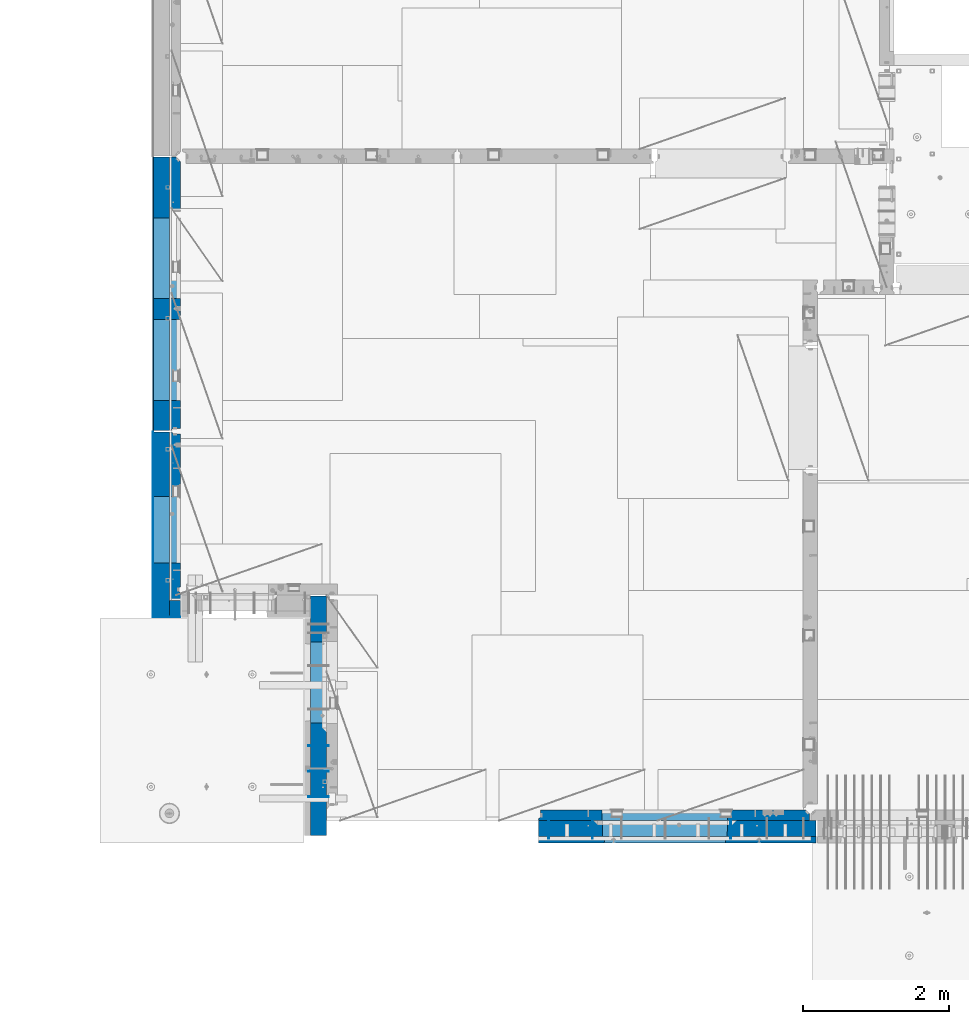
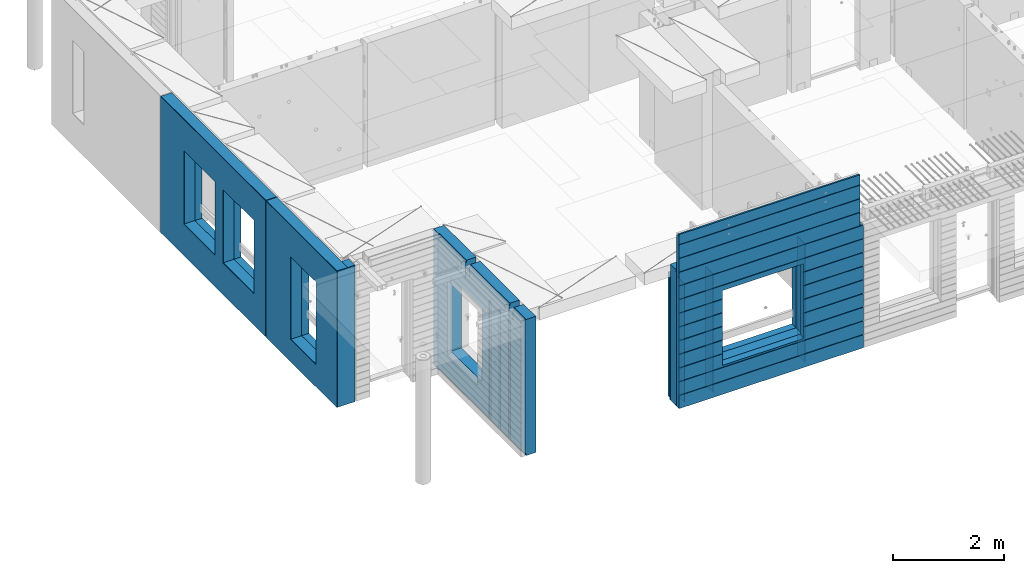
# One storey, part 192 of 309: 18 walls, 4 elements without a shape of their own.
"""IFC2X3 building model written with IfcOpenShell, lengths in millimetres."""

from ifc_helpers import new_model, si_unit, frame, origin_with_axes, place, context, subcontext, project, spatial, faceted_brep, material, type_object, element, aggregate, save


model = new_model("IFC2X3")

# Units and contexts
model_context = context("Model", 3, precision=1e-05, world=origin_with_axes())
body_context = subcontext(model_context, "Body", "Model", "MODEL_VIEW")
ifc_project = project(units=[si_unit("LENGTHUNIT", "METRE", prefix="MILLI"), si_unit("AREAUNIT", "SQUARE_METRE"), si_unit("VOLUMEUNIT", "CUBIC_METRE"), si_unit("MASSUNIT", "GRAM", prefix="KILO"), si_unit("TIMEUNIT", "SECOND"), si_unit("PLANEANGLEUNIT", "RADIAN"), si_unit("SOLIDANGLEUNIT", "STERADIAN"), si_unit("THERMODYNAMICTEMPERATUREUNIT", "DEGREE_CELSIUS"), si_unit("LUMINOUSINTENSITYUNIT", "LUMEN")], contexts=[model_context])

# Site, building, storey
site_placement = place(None, origin_with_axes())
site = spatial("IfcSite", under=ifc_project, at=site_placement, CompositionType="ELEMENT")
building_placement = place(site_placement, origin_with_axes())
building = spatial("IfcBuilding", under=site, at=building_placement, CompositionType="ELEMENT")
storey_placement = place(building_placement, origin_with_axes())
storey = spatial("IfcBuildingStorey", under=building, at=storey_placement, Name="7", CompositionType="ELEMENT", Elevation=0.0)

# Assembly, walls
assembly_1_placement = place(storey_placement, origin_with_axes())
assembly_1 = element("IfcElementAssembly", 1, at=assembly_1_placement, inside=storey, AssemblyPlace="NOTDEFINED", PredefinedType="REINFORCEMENT_UNIT")
ifc_material_1 = material(Name="Undefined")
wall_type_1 = type_object("IfcWallType", PredefinedType="NOTDEFINED")
wall_1_placement = place(assembly_1_placement, frame((13665.0, 7880.0, 101115.0), z_axis=(0.0, 0.0, 1.0), x_axis=(0.0, -1.0, 0.0)))
wall_1 = element("IfcWall", 2, at=wall_1_placement, type_object=wall_type_1, material=ifc_material_1, Name="(PD)", context=body_context, shape_type="Brep", body=[
    faceted_brep([(0.0, 5.0, -1300.0), (0.0, 5.0, 1300.0), (280.0, 5.0, 1300.0), (280.0, 5.0, -1300.0), (0.0, -5.0, 1300.0), (280.0, -5.0, 1300.0), (0.0, -5.0, -1300.0), (280.0, -5.0, -1300.0)], [[[0, 1, 2, 3]], [[1, 4, 5, 2]], [[4, 6, 7, 5]], [[6, 0, 3, 7]], [[5, 7, 3, 2]], [[6, 4, 1, 0]]]),
])
wall_2_placement = place(assembly_1_placement, frame((13065.0, 7880.0, 101115.0), z_axis=(0.0, 0.0, 1.0), x_axis=(0.0, -1.0, 0.0)))
wall_2 = element("IfcWall", 3, at=wall_2_placement, type_object=wall_type_1, material=ifc_material_1, Name="(PD)", context=body_context, shape_type="Brep", body=[
    faceted_brep([(0.0, 5.0, -1300.0), (0.0, 5.0, 1300.0), (280.0, 5.0, 1300.0), (280.0, 5.0, -1300.0), (0.0, -5.0, 1300.0), (280.0, -5.0, 1300.0), (0.0, -5.0, -1300.0), (280.0, -5.0, -1300.0)], [[[0, 1, 2, 3]], [[1, 4, 5, 2]], [[4, 6, 7, 5]], [[6, 0, 3, 7]], [[5, 7, 3, 2]], [[6, 4, 1, 0]]]),
])
wall_3_placement = place(assembly_1_placement, frame((15565.0, 7880.0, 101115.0), z_axis=(0.0, 0.0, 1.0), x_axis=(0.0, -1.0, 0.0)))
wall_3 = element("IfcWall", 4, at=wall_3_placement, type_object=wall_type_1, material=ifc_material_1, Name="(PD)", context=body_context, shape_type="Brep", body=[
    faceted_brep([(0.0, 5.0, -1300.0), (0.0, 5.0, 1300.0), (280.0, 5.0, 1300.0), (280.0, 5.0, -1300.0), (0.0, -5.0, 1300.0), (280.0, -5.0, 1300.0), (0.0, -5.0, -1300.0), (280.0, -5.0, -1300.0)], [[[0, 1, 2, 3]], [[1, 4, 5, 2]], [[4, 6, 7, 5]], [[6, 0, 3, 7]], [[5, 7, 3, 2]], [[6, 4, 1, 0]]]),
])

assembly_2_placement = place(storey_placement, origin_with_axes())
assembly_2 = element("IfcElementAssembly", 5, at=assembly_2_placement, inside=storey, AssemblyPlace="NOTDEFINED", PredefinedType="REINFORCEMENT_UNIT")
wall_4_placement = place(assembly_2_placement, frame((10040.0, 8180.0, 101115.0), z_axis=(0.0, 0.0, 1.0), x_axis=(-1.0, 3.00000001838171e-08, 0.0)))
wall_4 = element("IfcWall", 6, at=wall_4_placement, type_object=wall_type_1, material=ifc_material_1, Name="(PD)", context=body_context, shape_type="Brep", body=[
    faceted_brep([(0.0, 5.0, -1300.0), (0.0, 5.0, 1300.0), (280.0, 5.0, 1300.0), (280.0, 5.0, -1300.0), (0.0, -5.0, 1300.0), (280.0, -5.0, 1300.0), (0.0, -5.0, -1300.0), (280.0, -5.0, -1300.0)], [[[0, 1, 2, 3]], [[1, 4, 5, 2]], [[4, 6, 7, 5]], [[6, 0, 3, 7]], [[5, 7, 3, 2]], [[6, 4, 1, 0]]]),
])
wall_5_placement = place(assembly_2_placement, frame((10040.0, 8530.0, 101115.0), z_axis=(0.0, 0.0, 1.0), x_axis=(-1.0, 3.00000001838171e-08, 0.0)))
wall_5 = element("IfcWall", 7, at=wall_5_placement, type_object=wall_type_1, material=ifc_material_1, Name="(PD)", context=body_context, shape_type="Brep", body=[
    faceted_brep([(0.0, 5.0, -1300.0), (0.0, 5.0, 1300.0), (280.0, 5.0, 1300.0), (280.0, 5.0, -1300.0), (0.0, -5.0, 1300.0), (280.0, -5.0, 1300.0), (0.0, -5.0, -1300.0), (280.0, -5.0, -1300.0)], [[[0, 1, 2, 3]], [[1, 4, 5, 2]], [[4, 6, 7, 5]], [[6, 0, 3, 7]], [[5, 7, 3, 2]], [[6, 4, 1, 0]]]),
])
wall_6_placement = place(assembly_2_placement, frame((10040.0, 8880.0, 101115.0), z_axis=(0.0, 0.0, 1.0), x_axis=(-1.0, 3.00000001838171e-08, 0.0)))
wall_6 = element("IfcWall", 8, at=wall_6_placement, type_object=wall_type_1, material=ifc_material_1, Name="(PD)", context=body_context, shape_type="Brep", body=[
    faceted_brep([(0.0, 5.0, -1300.0), (0.0, 5.0, 1300.0), (280.0, 5.0, 1300.0), (280.0, 5.0, -1300.0), (0.0, -5.0, 1300.0), (280.0, -5.0, 1300.0), (0.0, -5.0, -1300.0), (280.0, -5.0, -1300.0)], [[[0, 1, 2, 3]], [[1, 4, 5, 2]], [[4, 6, 7, 5]], [[6, 0, 3, 7]], [[5, 7, 3, 2]], [[6, 4, 1, 0]]]),
])

# Wall
ifc_material_2 = material(Name="COS5gt")
wall_type_2 = type_object("IfcWallType", PredefinedType="NOTDEFINED")
wall_7_placement = place(assembly_1_placement, frame((16740.0, 7740.0, 101247.5), z_axis=(0.0, 0.0, 1.0), x_axis=(-1.0, 3.00000001838171e-08, 0.0)))
wall_7 = element("IfcWall", 9, at=wall_7_placement, type_object=wall_type_2, material=ifc_material_2, context=body_context, shape_type="Brep", body=[
    faceted_brep([(70.0000000000073, -110.0, 1492.5), (70.0000000000073, 90.0, 1492.5), (70.0000000000073, 90.0, 1442.5), (70.0000000000073, 110.0, 1442.5), (70.0000000000073, 110.001496094053, 1202.50000000001), (70.0000000000073, -109.998503905947, 1202.50000000001), (0.0, -109.998503905947, 1202.50000000001), (0.0, 110.0, 1202.50000000001), (3820.0, 90.0, 1442.5), (3820.0, 110.0, 1442.5), (3820.0, 90.0, 1492.5), (3820.0, -110.0, 1492.5), (0.0, 110.0, -1442.5), (3820.0, 110.0, -1442.5), (3820.0, 90.0, -1442.5), (0.0, 90.0, -1442.5), (3820.0, -110.0, -1492.5), (3820.0, 90.0, -1492.5), (0.0, 90.0, -1492.5), (0.0, -110.0, -1492.5), (1224.99975425761, 110.0, -807.5), (1254.99975425761, 110.0, -807.5), (2904.99975425761, 110.0, -807.5), (2934.99975425761, 110.0, -807.5), (2934.99975425761, 110.0, -802.5), (2934.99975425761, 110.0, 807.5), (1224.99975425761, 110.0, 807.5), (1224.99975425761, 110.0, -802.5), (1219.05380831167, -110.0, -813.445945945947), (1219.05380831167, -110.0, 813.445945945947), (2940.94570020356, -110.0, -813.445945945947), (2940.94570020356, -110.0, 813.445945945947)], [[[0, 1, 2, 3, 4, 5]], [[6, 5, 4, 7]], [[8, 9, 3, 2]], [[10, 8, 2, 1]], [[11, 10, 1, 0]], [[12, 13, 14, 15]], [[9, 8, 10, 11, 16, 17, 14, 13]], [[15, 14, 17, 18]], [[16, 19, 18, 17]], [[12, 15, 18, 19, 6, 7]], [[3, 9, 13, 12, 7, 4], [20, 21, 22, 23, 24, 25, 26, 27]], [[28, 20, 27, 26, 29]], [[30, 23, 22, 21, 20, 28]], [[24, 23, 30, 31, 25]], [[29, 26, 25, 31]], [[19, 16, 11, 0, 5, 6], [30, 28, 29, 31]]]),
])

# Assembly, wall
assembly_3_placement = place(storey_placement, origin_with_axes())
assembly_3 = element("IfcElementAssembly", 10, at=assembly_3_placement, inside=storey, AssemblyPlace="NOTDEFINED", PredefinedType="REINFORCEMENT_UNIT")
ifc_material_3 = material()
wall_8_placement = place(assembly_3_placement, frame((8000.00051558999, 10765.0000158944, 101247.5), z_axis=(0.0, 0.0, 1.0), x_axis=(-0.999999999997437, -2.26400000064461e-06, 0.0)))
wall_8 = element("IfcWall", 11, at=wall_8_placement, type_object=wall_type_2, material=ifc_material_3, context=body_context, shape_type="Brep", body=[
    faceted_brep([(0.0, 110.0, -1492.5), (0.0, 110.0, 1492.5), (150.000694320282, 109.999999999998, 1492.5), (150.000694320282, 109.999999999998, -1492.5), (0.0, -110.0, 1492.5), (150.000694320282, -110.000000000004, 1492.5), (0.0, -110.0, -1492.5), (150.000694320282, -110.000000000004, -1492.5)], [[[0, 1, 2, 3]], [[1, 4, 5, 2]], [[4, 6, 7, 5]], [[6, 0, 3, 7]], [[5, 7, 3, 2]], [[6, 4, 1, 0]]]),
])

# Wall
wall_9_placement = place(assembly_2_placement, frame((9900.0, 8000.0, 101247.5), z_axis=(0.0, 0.0, 1.0), x_axis=(0.0, 1.0, 0.0)))
wall_9 = element("IfcWall", 12, at=wall_9_placement, type_object=wall_type_2, material=ifc_material_2, context=body_context, shape_type="Brep", body=[
    faceted_brep([(-335.0, 110.0, 1442.5), (-335.0, 90.0, 1442.5), (79.9999999999982, 90.0, 1442.5), (79.9999999999982, 110.0, 1442.5), (2751.0, 90.0, 1492.5), (2751.0, 90.0, 1442.5), (1785.0, 90.0, 1442.5), (1785.0, 90.0, 1492.5), (2751.0, 110.0, 1492.5), (2751.0, 110.0, 1442.5), (1785.0, 110.0, 1442.5), (1635.0, -110.0, 1492.5), (1635.0, 90.0, 1492.5), (229.999999999998, 90.0, 1492.5), (229.999999999998, -110.0, 1492.5), (1635.0, 90.0, 1442.5), (1635.0, 110.0, 1442.5), (229.999999999998, 110.0, 1442.5), (229.999999999998, 90.0, 1442.5), (1635.0, -110.0, 1222.5), (1635.0, 110.0, 1222.5), (1785.0, -110.0, 1222.5), (1785.0, 110.0, 1222.5), (1785.0, -110.0, 1492.5), (2935.0, -110.0, 1492.5), (2935.0, 110.0, 1492.5), (2935.0, -110.0, -1492.5), (2935.0, 110.0, -1492.5), (-355.0, -110.0, -1492.5), (-355.0, 90.0, -1492.5), (2751.0, 90.0, -1492.5), (2751.0, 110.0, -1492.5), (-355.0, 110.0, -1442.5), (2751.0, 110.0, -1442.5), (2751.0, 90.0, -1442.5), (-355.0, 90.0, -1442.5), (-355.0, -110.0, 1492.5), (-355.0, 110.0, 1492.5), (-335.0, 90.0, 1492.5), (-335.0, 110.0, 1492.5), (79.9999999999982, -110.0, 1492.5), (79.9999999999982, 90.0, 1492.5), (79.9999999999982, -110.0, 1222.5), (79.9999999999982, 110.0, 1222.5), (229.999999999998, -110.0, 1222.5), (229.999999999998, 110.0, 1222.5), (1189.05717134203, -110.0, -813.445945945859), (1189.05717134203, -110.0, 813.445945945859), (2310.94906323375, -110.0, 813.445945945859), (2310.94906323375, -110.0, -813.445945945859), (1195.00311728789, 109.999999996904, -807.5), (1195.00311728789, 109.999999996904, -802.5), (1195.00311728789, 109.999999996904, 807.5), (2305.00311728789, 109.999999996904, -807.5), (2275.00311728789, 109.999999996904, -807.5), (1225.00311728789, 109.999999996904, -807.5), (2305.00311728789, 109.999999996904, 807.5), (2305.00311728789, 109.999999996904, -802.5)], [[[0, 1, 2, 3]], [[4, 5, 6, 7]], [[8, 9, 5, 4]], [[5, 9, 10, 6]], [[11, 12, 13, 14]], [[15, 16, 17, 18]], [[12, 15, 18, 13]], [[11, 19, 20, 16, 15, 12]], [[21, 22, 20, 19]], [[23, 7, 6, 10, 22, 21]], [[24, 25, 8, 4, 7, 23]], [[24, 26, 27, 25]], [[27, 26, 28, 29, 30, 31]], [[32, 33, 34, 35]], [[30, 34, 33, 31]], [[29, 35, 34, 30]], [[28, 36, 37, 32, 35, 29]], [[38, 39, 37, 36, 40, 41]], [[1, 38, 41, 2]], [[40, 42, 43, 3, 2, 41]], [[44, 45, 43, 42]], [[14, 13, 18, 17, 45, 44]], [[42, 40, 36, 28, 26, 24, 23, 21, 19, 11, 14, 44], [46, 47, 48, 49]], [[46, 50, 51, 52, 47]], [[49, 53, 54, 55, 50, 46]], [[48, 56, 57, 53, 49]], [[47, 52, 56, 48]], [[16, 20, 22, 10, 9, 8, 25, 27, 31, 33, 32, 37, 39, 0, 3, 43, 45, 17], [51, 50, 55, 54, 53, 57, 56, 52]], [[38, 1, 0, 39]]]),
])

aggregate(assembly_2, [wall_4, wall_5, wall_6, wall_9])

# Assembly, wall
assembly_4_placement = place(storey_placement, origin_with_axes())
assembly_4 = element("IfcElementAssembly", 13, at=assembly_4_placement, inside=storey, AssemblyPlace="NOTDEFINED", PredefinedType="REINFORCEMENT_UNIT")
wall_10_placement = place(assembly_4_placement, frame((7739.99972588711, 13210.0004309454, 101247.5), z_axis=(0.0, 0.0, 1.0), x_axis=(0.0, 1.0, 0.0)))
wall_10 = element("IfcWall", 14, at=wall_10_placement, type_object=wall_type_2, material=ifc_material_3, context=body_context, shape_type="Brep", body=[
    faceted_brep([(0.0, 110.0, 1492.5), (0.0, -110.0, 1492.5), (3759.99957708461, -110.0, 1492.5), (3759.99956102462, 110.0, 1492.5), (0.0, -110.0, -1492.5), (0.0, 110.0, -1492.5), (3759.99956102462, 110.0, -1492.5), (3759.99957708461, -110.0, -1492.5), (414.999554466332, -110.0, -802.5), (414.999554466332, -110.0, 807.5), (1524.99955446633, -110.000000000001, 807.5), (1524.99955446633, -110.000000000001, -802.5), (1814.99999876569, -110.0, -802.5), (1814.99999876569, -110.0, 807.5), (2924.99999876569, -110.0, 807.5), (2924.99999876569, -110.0, -802.5), (1814.99999876569, 110.0, -802.5), (1814.99999876569, 110.0, 807.5), (2924.99999876569, 110.0, -802.5), (2924.99999876569, 110.0, 807.5), (414.999554466332, 110.0, -802.5), (1524.99955446633, 109.999999999999, -802.5), (1524.99955446633, 109.999999999999, 807.5), (414.999554466332, 110.0, 807.5)], [[[0, 1, 2, 3]], [[4, 1, 0, 5]], [[4, 5, 6, 7]], [[2, 7, 6, 3]], [[1, 4, 7, 2], [8, 9, 10, 11], [12, 13, 14, 15]], [[12, 16, 17, 13]], [[15, 18, 16, 12]], [[14, 19, 18, 15]], [[13, 17, 19, 14]], [[5, 0, 3, 6], [20, 21, 22, 23], [16, 18, 19, 17]], [[10, 22, 21, 11]], [[9, 23, 22, 10]], [[8, 20, 23, 9]], [[11, 21, 20, 8]]]),
])

# Wall
wall_11_placement = place(assembly_3_placement, frame((7740.00002947772, 10874.9996836349, 101247.5), z_axis=(0.0, 0.0, 1.0), x_axis=(0.0, 1.0, 0.0)))
wall_11 = element("IfcWall", 15, at=wall_11_placement, type_object=wall_type_2, material=ifc_material_3, context=body_context, shape_type="Brep", body=[
    faceted_brep([(-219.99966922487, -110.0, 1492.5), (-219.99966922487, -110.0, -1492.5), (2320.00069431996, -110.000000000001, -1492.5), (2320.00069431996, -110.000000000001, 1492.5), (520.000578694053, -110.000000000001, -1002.5), (520.000578694053, -110.000000000001, 807.5), (1430.00057869405, -110.000000000001, 807.5), (1430.00057869405, -110.000000000001, -1002.5), (-219.99966922487, 110.0, 1492.5), (2320.00069431997, 110.0, 1492.5), (-219.99966922487, 110.0, -1492.5), (2320.00069431997, 110.0, -1492.5), (520.000578694055, 110.0, -1002.5), (1430.00057869406, 110.0, -1002.5), (1430.00057869406, 110.0, 807.5), (520.000578694055, 110.0, 807.5)], [[[0, 1, 2, 3], [4, 5, 6, 7]], [[8, 0, 3, 9]], [[1, 0, 8, 10]], [[1, 10, 11, 2]], [[3, 2, 11, 9]], [[10, 8, 9, 11], [12, 13, 14, 15]], [[6, 14, 13, 7]], [[5, 15, 14, 6]], [[4, 12, 15, 5]], [[7, 13, 12, 4]]]),
])

ifc_material_4 = material(Name="CONCRETE/C25/30")
wall_type_3 = type_object("IfcWallType", PredefinedType="NOTDEFINED")
wall_12_placement = place(assembly_1_placement, frame((16660.0, 7925.0, 101112.5), z_axis=(0.0, 0.0, 1.0), x_axis=(-1.0, 3.00000001838171e-08, 0.0)))
wall_12 = element("IfcWall", 16, at=wall_12_placement, type_object=wall_type_3, material=ifc_material_4, context=body_context, shape_type="Brep", body=[
    faceted_brep([(10.0, 75.0, 1357.5), (10.0, 75.0, -1357.5), (10.0, -15.0, -1357.5), (10.0, -15.0, 1357.5), (70.0, -75.0, -1357.5), (3740.00000000003, 75.0, -1357.5), (3740.00000000003, 45.0, -1357.5), (3707.5, 32.0, -1357.5), (3707.5, -75.0, -1357.5), (70.0, -75.0, 1357.5), (3740.00000000003, 45.0, 1357.5), (3740.00000000003, 75.0, 1357.5), (3707.5, -75.0, 1357.5), (3707.5, 32.0, 1357.5), (2864.99975425761, -75.0, -682.5), (1134.99975425761, -75.0, -682.5), (1134.99975425761, -75.0, 952.5), (2864.99975425761, -75.0, 952.5), (2860.94570020356, 75.0, -678.445945945947), (1139.05380831167, 75.0, -678.445945945947), (1139.05380831167, 75.0, 948.445945945947), (2860.94570020356, 75.0, 948.445945945947)], [[[0, 1, 2, 3]], [[4, 2, 1, 5, 6, 7, 8]], [[3, 2, 4, 9]], [[10, 11, 0, 3, 9, 12, 13]], [[5, 11, 10, 6]], [[13, 7, 6, 10]], [[12, 8, 7, 13]], [[9, 4, 8, 12], [14, 15, 16, 17]], [[14, 18, 19, 15]], [[15, 19, 20, 16]], [[1, 0, 11, 5], [18, 21, 20, 19]], [[16, 20, 21, 17]], [[18, 14, 17, 21]]]),
])

wall_13_placement = place(assembly_4_placement, frame((7924.99972588712, 13210.0004174405, 101112.5), z_axis=(0.0, 0.0, 1.0), x_axis=(0.0, 1.0, 0.0)))
wall_13 = element("IfcWall", 17, at=wall_13_placement, type_object=wall_type_3, material=ifc_material_4, context=body_context, shape_type="Brep", body=[
    faceted_brep([(1524.99955451006, -75.0000000617138, -667.5), (1524.99955451006, 75.0, -667.5), (414.999554510065, 75.0, -667.5), (414.999554510063, -75.000000114278, -667.5), (414.999554510065, 75.0, 942.5), (414.999554510063, -75.0000002207053, 942.5), (1524.99955451006, 75.0, 942.5), (1524.99955451006, -75.000000168141, 942.5), (0.0, 45.0, 1357.5), (0.0, 45.0, -1357.5), (29.9999989126591, 32.0000004547946, -1357.5), (29.9999989126591, 32.0000004547946, 1357.5), (0.0, 75.0, 1357.5), (0.0, 75.0, -1357.5), (3759.99957708464, 74.9999999999991, -1357.5), (3759.99957708464, 74.9999999999991, 1357.5), (3759.99958365464, -14.9999989005837, 1357.5), (3759.99958365464, -14.9999989005837, -1357.5), (30.0000016637459, -75.0, -1357.5), (3699.99959131522, -75.0000000000018, -1357.5), (30.0000016637459, -75.0, 1357.5), (3699.99959130954, -75.0000000056843, 1357.5), (1814.99999880942, -75.0000000486807, -667.5), (1814.99999880942, -75.0000001534236, 942.5), (2924.99999880942, -75.0000001008593, 942.5), (2924.99999880942, -74.9999999961165, -667.5), (1814.99999880942, 74.9999999999991, -667.5), (1814.99999880942, 74.9999999999991, 942.5), (2924.99999880942, 74.9999999999991, -667.5), (2924.99999880942, 74.9999999999991, 942.5)], [[[0, 1, 2, 3]], [[3, 2, 4, 5]], [[5, 4, 6, 7]], [[7, 6, 1, 0]], [[8, 9, 10, 11]], [[12, 13, 9, 8]], [[14, 15, 16, 17]], [[18, 10, 9, 13, 14, 17, 19]], [[11, 10, 18, 20]], [[15, 12, 8, 11, 20, 21, 16]], [[17, 16, 21, 19]], [[20, 18, 19, 21], [3, 5, 7, 0], [22, 23, 24, 25]], [[22, 26, 27, 23]], [[25, 28, 26, 22]], [[24, 29, 28, 25]], [[23, 27, 29, 24]], [[13, 12, 15, 14], [2, 1, 6, 4], [26, 28, 29, 27]]]),
])

wall_14_placement = place(assembly_3_placement, frame((7924.99999902025, 11107.4999902024, 101112.5), z_axis=(0.0, 0.0, 1.0), x_axis=(0.0, 1.0, 0.0)))
wall_14 = element("IfcWall", 18, at=wall_14_placement, type_object=wall_type_3, material=ifc_material_4, context=body_context, shape_type="Brep", body=[
    faceted_brep([(1197.50029630646, -74.9999998966041, -867.5), (1197.50029630646, 74.9999999999982, -867.5), (287.500296306462, 74.9999999999991, -867.5), (287.500296306462, -74.9999993964047, -867.5), (287.500296306462, 74.9999999999991, 942.5), (287.500296306462, -74.9999986286903, 942.5), (1197.50029630646, 74.9999999999982, 942.5), (1197.50029630646, -74.9999991288896, 942.5), (2087.5004119875, 44.9999999972642, 1357.5), (2087.5004119875, 74.9999999999991, 1357.5), (-232.500282332605, 74.9999999999991, 1357.5), (-232.500282332603, -75.0000000000009, 1357.5), (-122.50000002761, -75.0000000000009, 1357.5), (-109.499996997054, -54.9999860283524, 1357.5), (-55.4999970925001, -54.9999931295279, 1357.5), (-42.4999972430833, -74.9999976941244, 1357.5), (2057.50041198727, -75.0000000027349, 1357.5), (2057.50041198727, 24.9999999972651, 1357.5), (-232.500282332603, -75.0000000000009, -1357.5), (-232.500282332605, 74.9999999999991, -1357.5), (-122.50000002761, -75.0000000000009, -1357.5), (-109.499996997054, -54.9999860283524, -1357.5), (-55.4999970925001, -54.9999931295279, -1357.5), (-42.4999972430851, -75.0000000000009, -1357.5), (2057.50041198727, -75.0000000000009, -1357.5), (2057.50041198727, 24.9999999972651, -1357.5), (2087.5004119875, 74.9999999999991, -1357.5), (2087.5004119875, 44.9999999972642, -1357.5)], [[[0, 1, 2, 3]], [[3, 2, 4, 5]], [[5, 4, 6, 7]], [[7, 6, 1, 0]], [[8, 9, 10, 11, 12, 13, 14, 15, 16, 17]], [[18, 11, 10, 19]], [[11, 18, 20, 12]], [[12, 20, 21, 13]], [[13, 21, 22, 14]], [[15, 14, 22, 23]], [[15, 23, 24, 16], [3, 5, 7, 0]], [[16, 24, 25, 17]], [[23, 22, 21, 20, 18, 19, 26, 27, 25, 24]], [[17, 25, 27, 8]], [[26, 9, 8, 27]], [[19, 10, 9, 26], [2, 1, 6, 4]]]),
])

ifc_material_5 = material(Name="CONCRETE/C30/37")
wall_type_4 = type_object("IfcWallType", PredefinedType="NOTDEFINED")
wall_15_placement = place(assembly_3_placement, frame((8000.00033490857, 10650.0000304601, 101247.5), z_axis=(0.0, 0.0, 1.0), x_axis=(-1.0, 3.00000001838171e-08, 0.0)))
wall_15 = element("IfcWall", 19, at=wall_15_placement, type_object=wall_type_4, material=ifc_material_5, context=body_context, shape_type="Brep", body=[
    faceted_brep([(0.0, 5.0, -1492.5), (0.0, 5.0, 1492.5), (370.000694320092, 4.99999999999818, 1492.5), (370.000694320092, 4.99999999999818, -1492.5), (0.0, -5.0, 1492.5), (370.000694320092, -5.0, 1492.5), (0.0, -5.0, -1492.5), (370.000694320092, -5.0, -1492.5)], [[[0, 1, 2, 3]], [[1, 4, 5, 2]], [[4, 6, 7, 5]], [[6, 0, 3, 7]], [[5, 7, 3, 2]], [[6, 4, 1, 0]]]),
])

wall_16_placement = place(assembly_4_placement, frame((7624.9997258871, 13210.0004393404, 101247.5), z_axis=(0.0, 0.0, 1.0), x_axis=(0.0, 1.0, 0.0)))
wall_16 = element("IfcWall", 20, at=wall_16_placement, type_object=wall_type_4, material=ifc_material_5, context=body_context, shape_type="Brep", body=[
    faceted_brep([(0.0, 5.0, 1492.5), (0.0, -5.0, 1492.5), (3759.99956102465, -5.00000000000091, 1492.5), (3759.99956029465, 4.99999999999909, 1492.5), (0.0, -5.0, -1492.5), (0.0, 5.0, -1492.5), (3759.99956029465, 4.99999999999909, -1492.5), (3759.99956102465, -5.00000000000091, -1492.5), (414.999554402322, -5.00000000000091, -802.5), (414.999554402322, -5.00000000000091, 807.5), (1524.99955440232, -5.00000000000182, 807.5), (1524.99955440232, -5.00000000000182, -802.5), (1814.99999870163, -5.00000000000091, -802.5), (1814.99999870163, -5.00000000000091, 807.5), (2924.99999870163, -5.00000000000091, 807.5), (2924.99999870163, -5.00000000000091, -802.5), (1814.99999870163, 4.99999999999909, -802.5), (1814.99999870163, 4.99999999999909, 807.5), (2924.99999870163, 4.99999999999909, -802.5), (2924.99999870163, 4.99999999999909, 807.5), (414.999554402326, 4.99999999999818, -802.5), (1524.99955440232, 4.99999999999818, -802.5), (1524.99955440232, 4.99999999999818, 807.5), (414.999554402326, 4.99999999999818, 807.5)], [[[0, 1, 2, 3]], [[4, 1, 0, 5]], [[4, 5, 6, 7]], [[2, 7, 6, 3]], [[1, 4, 7, 2], [8, 9, 10, 11], [12, 13, 14, 15]], [[12, 16, 17, 13]], [[15, 18, 16, 12]], [[14, 19, 18, 15]], [[13, 17, 19, 14]], [[5, 0, 3, 6], [20, 21, 22, 23], [16, 18, 19, 17]], [[10, 22, 21, 11]], [[9, 23, 22, 10]], [[8, 20, 23, 9]], [[11, 21, 20, 8]]]),
])

aggregate(assembly_4, [wall_16, wall_10, wall_13])

wall_17_placement = place(assembly_3_placement, frame((7625.00002947765, 10874.99966857, 101247.5), z_axis=(0.0, 0.0, 1.0), x_axis=(0.0, 1.0, 0.0)))
wall_17 = element("IfcWall", 21, at=wall_17_placement, type_object=wall_type_4, material=ifc_material_5, context=body_context, shape_type="Brep", body=[
    faceted_brep([(-230.0, -5.0, 1492.5), (-230.0, -5.0, -1492.5), (2320.00069431993, -5.0, -1492.5), (2320.00069431993, -5.0, 1492.5), (520.000578774374, -5.0, -1002.5), (520.000578774374, -5.0, 807.5), (1430.00057877438, -5.0, 807.5), (1430.00057877438, -5.0, -1002.5), (-230.0, 5.0, 1492.5), (2320.00069431993, 5.0, 1492.5), (-230.0, 5.0, -1492.5), (2320.00069431993, 5.0, -1492.5), (520.000578774374, 5.0, -1002.5), (1430.00057877438, 5.0, -1002.5), (1430.00057877438, 5.0, 807.5), (520.000578774374, 5.0, 807.5)], [[[0, 1, 2, 3], [4, 5, 6, 7]], [[8, 0, 3, 9]], [[1, 0, 8, 10]], [[1, 10, 11, 2]], [[3, 2, 11, 9]], [[10, 8, 9, 11], [12, 13, 14, 15]], [[6, 14, 13, 7]], [[5, 15, 14, 6]], [[4, 12, 15, 5]], [[7, 13, 12, 4]]]),
])

aggregate(assembly_3, [wall_15, wall_8, wall_17, wall_11, wall_14])

wall_type_5 = type_object("IfcWallType", PredefinedType="NOTDEFINED")
wall_18_placement = place(assembly_1_placement, frame((16740.0, 7587.5, 101662.5), z_axis=(0.0, 0.0, 1.0), x_axis=(-1.0, 3.00000001838171e-08, 0.0)))
wall_18 = element("IfcWall", 22, at=wall_18_placement, type_object=wall_type_5, material=ifc_material_5, context=body_context, shape_type="Brep", body=[
    faceted_brep([(70.0000000000073, 7.5, 1907.5), (70.0, 7.5, 1857.5), (3820.0, 7.5, 1857.5), (3820.00000000003, 7.5, 1907.5), (70.0, -42.5, 1857.5), (3820.00000000003, -42.5, 1857.5), (0.0, -42.5, -1907.5), (0.0, 42.5, -1907.5), (3820.00000000003, 42.5, -1907.5), (3820.00000000003, -42.5, -1907.5), (0.0, 42.5, -1622.00000005524), (3820.00000000003, 42.5, -1622.00000005524), (0.0, 32.4999992501716, -1620.00000000076), (3820.00000000003, 32.4999992501716, -1620.00000000076), (0.0, 32.4999991121731, -1609.99999959956), (3820.00000000003, 32.4999991121731, -1609.99999959956), (0.0, 42.5, -1608.00000011075), (3820.00000000003, 42.5, -1608.00000011075), (0.0, 42.5, -1322.00000005524), (3820.00000000003, 42.5, -1322.00000005524), (0.0, 32.4999992501716, -1320.00000000076), (3820.00000000003, 32.4999992501716, -1320.00000000076), (0.0, 32.4999991121731, -1309.99999959956), (3820.00000000003, 32.4999991121731, -1309.99999959956), (0.0, 42.5, -1308.00000011075), (3820.00000000003, 42.5, -1308.00000011075), (3820.00000000003, 32.4999992501716, -1020.00000000076), (3820.00000000003, 42.5, -1022.00000005524), (2914.99975425761, 42.5, -1022.00000005524), (2913.82328358116, 32.4999992501716, -1020.00000000076), (3820.00000000003, 32.4999991121731, -1009.99999959956), (2913.82328356493, 32.4999991121731, -1009.99999959956), (3820.00000000003, 42.5, -1008.00000011075), (2914.99975425761, 42.5, -1008.00000011075), (3820.00000000003, 42.5, -722.000000055239), (2914.99975425761, 42.5, -722.000000055239), (3820.00000000003, 32.4999992501716, -720.000000000757), (2913.82328358116, 32.4999992501716, -720.000000000757), (3820.00000000003, 32.4999991121731, -709.99999959956), (2913.82328356493, 32.4999991121731, -709.99999959956), (3820.00000000003, 42.5, -708.000000110755), (2914.99975425761, 42.5, -708.000000110755), (3820.00000000003, 42.5, -422.000000055239), (2914.99975425761, 42.5, -422.000000055239), (3820.00000000003, 32.4999992501716, -420.000000000757), (2913.82328358116, 32.4999992501716, -420.000000000757), (3820.00000000003, 32.4999991121731, -409.99999959956), (2913.82328356493, 32.4999991121731, -409.99999959956), (3820.00000000003, 42.5, -408.000000110755), (2914.99975425761, 42.5, -408.000000110755), (3820.00000000003, 42.5, -122.000000055239), (2914.99975425761, 42.5, -122.000000055239), (3820.00000000002, 32.4999992501716, -120.000000000757), (2913.82328358116, 32.4999992501716, -120.000000000757), (3820.00000000002, 32.4999991121731, -109.99999959956), (2913.82328356493, 32.4999991121731, -109.99999959956), (3820.00000000003, 42.5, -108.000000110755), (2914.99975425761, 42.5, -108.000000110755), (3820.00000000003, 42.5, 177.999999944761), (2914.99975425761, 42.5, 177.999999944761), (3820.00000000002, 32.4999992501716, 179.999999999243), (2913.82328358116, 32.4999992501716, 179.999999999243), (3820.00000000002, 32.4999991121731, 190.00000040044), (2913.82328356493, 32.4999991121731, 190.00000040044), (3820.00000000003, 42.5, 191.999999889245), (2914.99975425761, 42.5, 191.999999889245), (3820.00000000003, 42.5, 1907.5), (3820.00000000003, 42.5, 1691.99999988925), (70.0, 42.4999992426428, 1691.99999988925), (70.0000000000073, 42.5, 1907.5), (3820.00000000001, 32.4999991121731, 1690.00000040044), (70.0, 32.4999991121731, 1690.00000040044), (3820.00000000001, 32.4999992501689, 1679.99999999923), (70.0, 32.4999992501689, 1679.99999999923), (3820.00000000003, 42.5, 1677.99999994476), (70.0, 42.4999992675093, 1677.99999994476), (3820.00000000003, 42.5, 1391.99999988925), (70.0, 42.4999992426428, 1391.99999988925), (3820.00000000001, 32.4999991121731, 1390.00000040044), (70.0, 32.4999991121731, 1390.00000040044), (3820.00000000001, 32.4999992501689, 1379.99999999923), (70.0, 32.4999992501689, 1379.99999999923), (3820.00000000003, 42.5, 1377.99999994476), (70.0, 42.4999992675093, 1377.99999994476), (3820.00000000003, 42.5, 1091.99999988925), (70.0000000000073, 42.5, 1091.99999988925), (3820.00000000001, 32.4999991121731, 1090.00000040044), (70.0000000000073, 32.4999991121731, 1090.00000040044), (3820.00000000001, 32.4999992501716, 1079.99999999924), (70.0000000000073, 32.4999992501716, 1079.99999999924), (3820.00000000003, 42.5, 1077.99999994476), (70.0000000000073, 42.5, 1077.99999994476), (3820.00000000003, 42.5, 791.999999889245), (70.0000000000073, 42.5, 791.999999889245), (3820.00000000002, 32.4999991121731, 790.00000040044), (70.0000000000073, 32.4999991121731, 790.00000040044), (70.0000000000073, 32.4999991466739, 787.500000000015), (70.0000000000073, -42.5, 787.500000000015), (3820.00000000003, 42.5, 477.999999944761), (3820.00000000002, 32.4999992501716, 479.999999999243), (3820.00000000002, 32.4999991121731, 490.00000040044), (3820.00000000003, 42.5, 491.999999889245), (3820.00000000003, 42.5, 777.999999944761), (3820.00000000002, 32.4999992501716, 779.999999999243), (0.0, 32.4999992501716, 479.999999999243), (0.0, 42.5, 477.999999944761), (0.0, 32.4999991121731, 490.00000040044), (0.0, 42.5, 491.999999889245), (0.0, 42.5, 777.999999944761), (0.0, 32.4999992501716, 779.999999999243), (0.0, 32.499999146673, 787.500000000015), (0.0, -42.5, 787.500000000015), (0.0, 42.5, 191.999999889245), (0.0, 32.4999991121731, 190.00000040044), (0.0, 32.4999992501716, 179.999999999243), (0.0, 42.5, 177.999999944761), (0.0, 42.5, -108.000000110755), (0.0, 32.4999991121731, -109.99999959956), (0.0, 32.4999992501716, -120.000000000757), (0.0, 42.5, -122.000000055239), (0.0, 42.5, -408.000000110755), (0.0, 32.4999991121731, -409.99999959956), (0.0, 32.4999992501716, -420.000000000757), (0.0, 42.5, -422.000000055239), (0.0, 42.5, -708.000000110755), (0.0, 32.4999991121731, -709.99999959956), (0.0, 32.4999992501716, -720.000000000757), (0.0, 42.5, -722.000000055239), (0.0, 42.5, -1008.00000011075), (0.0, 32.4999991121731, -1009.99999959956), (0.0, 32.4999992501716, -1020.00000000076), (0.0, 42.5, -1022.00000005524), (1246.1762249503, 32.4999991121731, 190.00000040044), (1246.17622493406, 32.4999992501716, 179.999999999243), (1244.99975425761, 42.5, 177.999999944761), (1244.99975425761, 42.5, -108.000000110755), (1246.1762249503, 32.4999991121731, -109.99999959956), (1246.17622493406, 32.4999992501716, -120.000000000757), (1244.99975425761, 42.5, -122.000000055239), (1244.99975425761, 42.5, -408.000000110755), (1246.1762249503, 32.4999991121731, -409.99999959956), (1246.17622493406, 32.4999992501716, -420.000000000757), (1244.99975425761, 42.5, -422.000000055239), (1244.99975425761, 42.5, -708.000000110755), (1246.1762249503, 32.4999991121731, -709.99999959956), (1246.17622493406, 32.4999992501716, -720.000000000757), (1244.99975425761, 42.5, -722.000000055239), (1244.99975425761, 42.5, -1008.00000011075), (1246.1762249503, 32.4999991121731, -1009.99999959956), (1246.17622493406, 32.4999992501716, -1020.00000000076), (1244.99975425761, 42.5, -1022.00000005524), (2914.99975425761, 42.5, -1272.5), (1244.99975425761, 42.5, -1272.5), (1254.99975425761, -42.5, -1222.5), (2904.99975425761, -42.5, -1222.5), (2904.99975425761, -42.5, 367.5), (2904.99975425761, -42.5, 372.5), (2914.99975425761, 42.5, 367.5), (2904.99975425761, 42.5, 367.5), (1254.99975425761, 42.5, 367.5), (1244.99975425761, 42.5, 367.5), (1244.99975425761, 42.5, 191.999999889245), (1254.99975425761, -42.5, 372.5), (1254.99975425761, -42.5, 367.5)], [[[0, 1, 2, 3]], [[4, 5, 2, 1]], [[6, 7, 8, 9]], [[8, 7, 10, 11]], [[12, 13, 11, 10]], [[14, 15, 13, 12]], [[16, 17, 15, 14]], [[17, 16, 18, 19]], [[20, 21, 19, 18]], [[22, 23, 21, 20]], [[24, 25, 23, 22]], [[26, 27, 28, 29]], [[30, 26, 29, 31]], [[32, 30, 31, 33]], [[34, 32, 33, 35]], [[36, 34, 35, 37]], [[38, 36, 37, 39]], [[40, 38, 39, 41]], [[42, 40, 41, 43]], [[44, 42, 43, 45]], [[46, 44, 45, 47]], [[48, 46, 47, 49]], [[50, 48, 49, 51]], [[52, 50, 51, 53]], [[54, 52, 53, 55]], [[56, 54, 55, 57]], [[58, 56, 57, 59]], [[60, 58, 59, 61]], [[62, 60, 61, 63]], [[64, 62, 63, 65]], [[66, 67, 68, 69]], [[67, 70, 71, 68]], [[70, 72, 73, 71]], [[72, 74, 75, 73]], [[74, 76, 77, 75]], [[76, 78, 79, 77]], [[78, 80, 81, 79]], [[80, 82, 83, 81]], [[82, 84, 85, 83]], [[84, 86, 87, 85]], [[86, 88, 89, 87]], [[88, 90, 91, 89]], [[90, 92, 93, 91]], [[92, 94, 95, 93]], [[0, 69, 68, 71, 73, 75, 77, 79, 81, 83, 85, 87, 89, 91, 93, 95, 96, 97, 4, 1]], [[66, 69, 0, 3]], [[9, 8, 11, 13, 15, 17, 19, 21, 23, 25, 27, 26, 30, 32, 34, 36, 38, 40, 42, 44, 46, 48, 50, 52, 54, 56, 58, 60, 62, 64, 98, 99, 100, 101, 102, 103, 94, 92, 90, 88, 86, 84, 82, 80, 78, 76, 74, 72, 70, 67, 66, 3, 2, 5]], [[104, 99, 98, 105]], [[106, 100, 99, 104]], [[107, 101, 100, 106]], [[101, 107, 108, 102]], [[109, 103, 102, 108]], [[95, 94, 103, 109, 110, 96]], [[111, 97, 96, 110]], [[109, 108, 107, 106, 104, 105, 112, 113, 114, 115, 116, 117, 118, 119, 120, 121, 122, 123, 124, 125, 126, 127, 128, 129, 130, 131, 24, 22, 20, 18, 16, 14, 12, 10, 7, 6, 111, 110]], [[114, 113, 132, 133]], [[115, 114, 133, 134]], [[116, 115, 134, 135]], [[117, 116, 135, 136]], [[118, 117, 136, 137]], [[119, 118, 137, 138]], [[120, 119, 138, 139]], [[121, 120, 139, 140]], [[122, 121, 140, 141]], [[123, 122, 141, 142]], [[124, 123, 142, 143]], [[125, 124, 143, 144]], [[126, 125, 144, 145]], [[127, 126, 145, 146]], [[128, 127, 146, 147]], [[129, 128, 147, 148]], [[130, 129, 148, 149]], [[131, 130, 149, 150]], [[151, 28, 27, 25, 24, 131, 150, 152]], [[152, 153, 154, 151]], [[155, 156, 157, 65, 63, 61, 59, 57, 55, 53, 51, 49, 47, 45, 43, 41, 39, 37, 35, 33, 31, 29, 28, 151, 154]], [[112, 105, 98, 64, 65, 157, 158, 159, 160, 161]], [[113, 112, 161, 132]], [[160, 162, 163, 153, 152, 150, 149, 148, 147, 146, 145, 144, 143, 142, 141, 140, 139, 138, 137, 136, 135, 134, 133, 132, 161]], [[159, 158, 157, 156, 162, 160]], [[97, 111, 6, 9, 5, 4], [155, 154, 153, 163, 162, 156]]]),
])

aggregate(assembly_1, [wall_1, wall_2, wall_3, wall_18, wall_7, wall_12])

save(model, "model.ifc")
